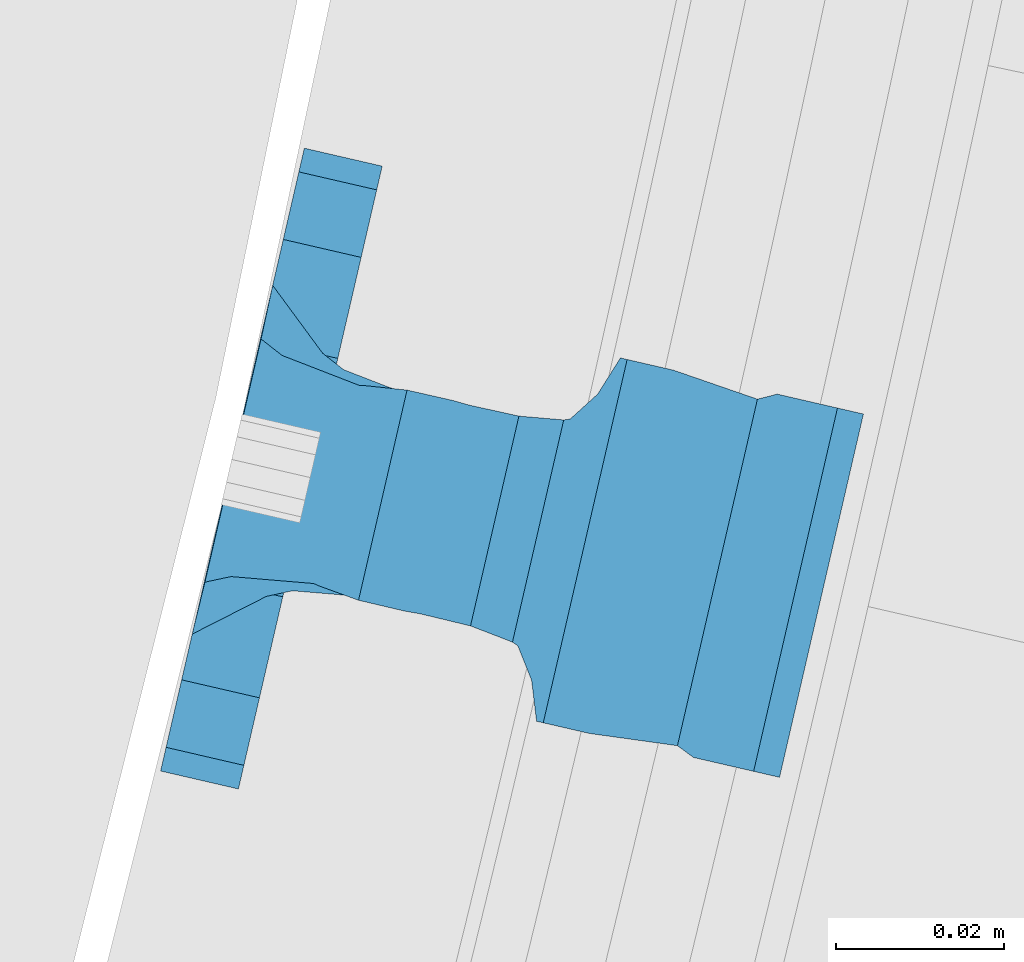
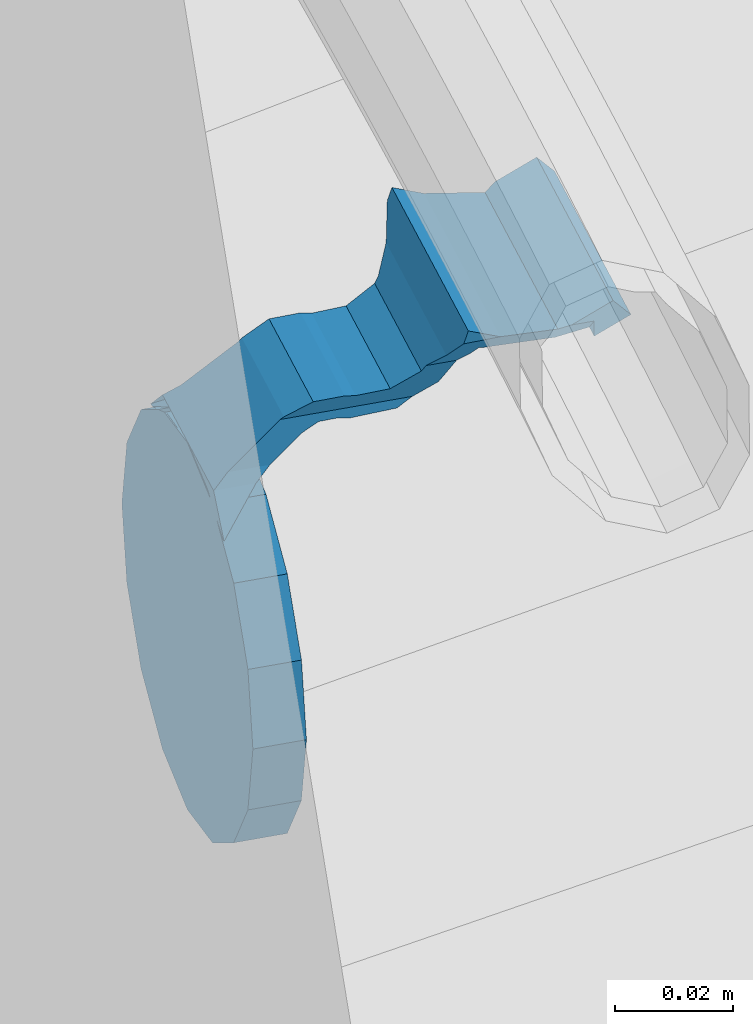
# One storey, part 504 of 975: 1 beam.
"""IFC2X3 building model written with IfcOpenShell, lengths in millimetres."""

from ifc_helpers import new_model, si_unit, frame, origin_with_axes, place, context, subcontext, project, spatial, faceted_brep, material, type_object, element, save


model = new_model("IFC2X3")

# Units and contexts
model_context = context("Model", 3, precision=1e-05, world=origin_with_axes())
body_context = subcontext(model_context, "Body", "Model", "MODEL_VIEW")
ifc_project = project(units=[si_unit("LENGTHUNIT", "METRE", prefix="MILLI"), si_unit("AREAUNIT", "SQUARE_METRE"), si_unit("VOLUMEUNIT", "CUBIC_METRE"), si_unit("MASSUNIT", "GRAM", prefix="KILO"), si_unit("TIMEUNIT", "SECOND"), si_unit("PLANEANGLEUNIT", "RADIAN"), si_unit("SOLIDANGLEUNIT", "STERADIAN"), si_unit("THERMODYNAMICTEMPERATUREUNIT", "DEGREE_CELSIUS"), si_unit("LUMINOUSINTENSITYUNIT", "LUMEN")], contexts=[model_context])

# Site, building, storey
site_placement = place(None, origin_with_axes())
site = spatial("IfcSite", under=ifc_project, at=site_placement, CompositionType="ELEMENT")
building_placement = place(site_placement, origin_with_axes())
building = spatial("IfcBuilding", under=site, at=building_placement, Name="Undefined", CompositionType="ELEMENT")
storey_placement = place(building_placement, origin_with_axes())
storey = spatial("IfcBuildingStorey", under=building, at=storey_placement, Name="Undefined", CompositionType="ELEMENT", Elevation=0.0)

# Beam
ifc_material = material(Name="STEEL/A36")
beam_type = type_object("IfcBeamType", PredefinedType="NOTDEFINED")
beam_placement = place(storey_placement, frame((38357.0730972042, 2567.26815130924, 1348.05855292862), z_axis=(0.224904224958235, 0.974380856819195, 0.000188308863012253), x_axis=(-0.974380874954763, 0.224904223989577, 2.35380000032316e-05)))
element("IfcBeam", 1, at=beam_placement, inside=storey, type_object=beam_type, material=ifc_material, Name="WALL BRACKET", context=body_context, shape_type="Brep", body=[
    faceted_brep([(-1.09139364212751e-11, -35.1998101886752, 14.5802387730655), (0.0, -26.940768363208, 26.9407683632162), (1.2732925824821e-11, -14.5802387731151, 35.1998101887366), (0.0, 0.0, 38.0999984741211), (3.27418092638254e-11, 14.5802387730973, 35.1998101888166), (3.45607986673713e-11, 26.9407683631939, 26.9407683633472), (3.27418092638254e-11, 35.1998101886679, 14.5802387732328), (2.36468622460961e-11, 38.0999999999908, 8.73114913702011e-11), (1.45519152283669e-11, 35.1998101886752, -14.5802387730655), (1.81898940354586e-12, 26.9407683632071, -26.9407683632162), (-1.09139364212751e-11, 14.5802387731146, -35.1998101887511), (0.0, 0.0, -38.0999984741211), (-2.91038304567337e-11, -14.5802387730978, -35.1998101888239), (-3.27418092638254e-11, -26.9407683631948, -26.9407683633617), (-3.09228198602796e-11, -35.1998101886688, -14.5802387732401), (-2.36468622460961e-11, -38.0999999999917, -9.45874489843845e-11), (9.52499999999407, 35.4440469783465, 13.3523775149006), (9.52500000001783, 38.099999999989, 1.23691279441118e-10), (5.45819490078651, 35.1998101886775, 14.58023877304), (5.15915812204861, 35.4440469814256, 13.3523774994246), (5.15916016817869, 35.4440461871586, -13.3523814925829), (5.45819607316758, 35.1998101886757, -14.5802387731565), (9.52499999563867, 35.4440461839649, -13.352381508641), (9.52499999999338, 33.7468954266617, -16.754679378646), (9.52499999999418, 26.9407683632057, -26.9407683631944), (7.23710514487385, 33.7468954167059, -16.7546793935435), (9.52499999997963, 14.5802387731133, -35.199810188722), (9.52499999996871, 7.73070496506989e-12, -38.1000000000931), (9.52499999996326, -14.5802387730996, -35.1998101888021), (9.52499999995962, -26.9407683631966, -26.9407683633399), (9.5249999999578, -35.1998101886768, -14.5802387731064), (9.52499999997235, -38.0999999999935, -7.27595761418343e-11), (9.52499999988504, -35.1998101886779, 14.5802387731401), (9.52499999999418, -26.9407683632098, 26.940768363238), (9.52500000000691, -14.5802387731169, 35.1998101887584), (9.52500000001783, -1.13686837721616e-11, 38.1000000001295), (9.5250000000251, 14.580238773096, 35.1998101888312), (9.52500000002692, 26.9407683631925, 26.9407683633617), (7.23710629084189, 33.7468933804012, 16.7546824409801), (9.52500001802099, 33.74689339, 16.7546824266137), (4.12737783423069, 36.2867482851609, 11.6630037101459), (9.52500001480979, 36.2867482910076, 11.6630037099276), (1.9072828969438, 38.0999998001848, -4.3824766180478e-06), (9.43529109937867, 38.0999998083389, -4.38277129433118e-06), (4.12738199474541, 36.2867456530334, -11.6630120660157), (9.52499999713365, 36.2867456588801, -11.6630120662267), (9.52499998931302, 31.8782691818908, -20.5007361535354), (1.90728516843444, 38.0999984362613, -14.9620414784949), (9.43529504267332, 38.0999984471014, -14.9620414798228), (9.52499998867484, 31.8782692100656, -21.3428983101403), (-0.974480980704527, 40.4536660864392, -13.6176374922397), (6.55352889353486, 40.4536660972792, -13.617637493564), (-3.23293929398841, 48.4467136552532, -12.2071016444133), (-3.86099316375032, 48.9596734302611, -12.3332393299024), (-3.86099415506237, 48.9596734359397, 12.1506042690053), (-3.23294234398753, 48.4467162038179, 12.0244673261113), (6.55352388489973, 40.4536689343606, 13.4350048968336), (9.4352891744017, 38.1000015670843, 14.7794093900302), (-8.88876894391092, 51.462646060533, -12.9487245784876), (-14.5044020842531, 51.5524567377918, -12.9708091785214), (-14.5044031272276, 51.5524567437842, 12.788173508583), (-8.88876998507754, 51.4626460665079, 12.7660889411018), (-16.4483770195459, 51.1442726592504, -12.8704360163174), (-16.4483780543928, 51.1442726651987, 12.6878004343525), (-22.5793182144077, 51.3711360271759, -12.9262221073186), (-22.5793192537777, 51.3711360331463, 12.7435864607032), (-27.8885284154861, 54.4455780358899, -13.6822326528272), (-27.8885295160832, 54.4455780422152, 13.4995963000001), (-28.6196515649072, 55.6169452716154, -13.9702738582564), (-31.1370083013608, 59.6501226213948, -17.5950925222933), (-31.1370097188383, 59.6501226295447, 17.4124524185645), (-28.6196545294583, 55.616948227025, 13.7876379643458), (-33.6296792490059, 67.324805151891, -22.2250062266612), (-32.8101722890036, 64.8016260361878, -22.2250061928717), (-39.3161821982224, 64.9509398614337, -22.2250064563596), (-33.6296810489844, 67.3248051619378, 22.2249937734341), (-39.3127719838823, 64.95236112884, 22.2249935438595), (-32.8101756191698, 64.8016307577993, 22.2249938072164), (-49.8281982508399, 63.7590297560901, -21.2879733583577), (-49.8281999673757, 63.7590297658239, 21.1053316176076), (-62.537662592724, 64.8016282183019, -22.2250073966388), (-62.5376643923654, 64.8016282284259, 22.2249926034456), (-59.3629825026719, 68.3509998487543, 22.2249927311568), (-59.3629807030303, 68.3509998386305, -22.2250072689349), (-56.0005505059879, 61.6533412669896, 22.2249928688907), (-56.0009816237271, 61.6535489521873, 19.2130312653135), (-56.0009816302269, 64.8016307505561, 22.0423689734525), (-51.9930603186979, 64.8016307660225, 22.2249930304133), (-51.9930486616773, 64.8016260085653, -22.2250069696784), (-56.000981616694, 61.6535497473442, -22.2250071312228), (-56.0009816212363, 64.8016260027941, -22.2250068759422), (-56.0009816161877, 61.6535496925769, -19.3956728877092), (-50.6240356350016, 59.0640018412871, -17.0683164176735), (-50.6240370098228, 59.0640018490833, 16.8856764812081), (-37.4851004069614, 60.555058921409, -18.4084041452843), (-37.4851018904596, 60.555058929803, 18.2257636742615), (-36.5628425975134, 60.9400579463424, -18.7544220673662), (-36.5628441090176, 60.9400579547794, 18.5717814508498), (-35.6661101826384, 58.1791091500552, -16.2730189810172), (-35.6661114930633, 58.1791091575863, 16.0903794298065), (-34.0669073739811, 55.616948225869, 13.7876379531408), (-34.0669044052501, 55.6169452637716, -13.9702738572996), (-31.199578137138, 51.0230652214489, -12.8406309028251), (-31.1995791695818, 51.0230652273826, 12.6579953160217), (-13.5258453474495, 46.8920843628518, -12.4814476045976), (-10.0158535806146, 46.8359491542703, -12.491353805628), (-10.0158545847443, 46.8359491600327, 12.308720278641), (-13.5258463507973, 46.8920843686235, 12.298814059428), (-15.4698202757649, 46.4839002842855, -12.5534799881534), (-15.469821284944, 46.4839002900824, 12.3708465294185), (-23.8996230795056, 46.7958284847284, -12.4984339079674), (-23.8996240842331, 46.7958284904998, 12.3158003666576), (-26.7505131823156, 48.4467136213889, -12.207101640266), (-26.7505186046602, 48.4467161988273, 12.0244672777189), (-6.87329577845111, 45.2714927334573, -12.7674339683217), (-6.87329680492121, 45.2714927393397, 12.584800790275), (-0.974485553301008, 40.4536689327629, 13.4350048813394), (1.90728014135857, 38.100001565487, 14.7794093745397), (9.52500002100476, 31.8782677827221, 21.320715892205), (9.52500002038346, 31.878267810155, 20.5007393728483)], [[[0, 1, 2, 3, 4, 5, 6, 7, 8, 9, 10, 11, 12, 13, 14, 15]], [[16, 17, 7, 6, 18, 19]], [[20, 21, 8, 7, 17, 22]], [[23, 24, 9, 8, 21, 25]], [[10, 9, 24, 26]], [[11, 10, 26, 27]], [[12, 11, 27, 28]], [[13, 12, 28, 29]], [[14, 13, 29, 30]], [[15, 14, 30, 31]], [[0, 15, 31, 32]], [[1, 0, 32, 33]], [[2, 1, 33, 34]], [[3, 2, 34, 35]], [[4, 3, 35, 36]], [[5, 4, 36, 37]], [[38, 18, 6, 5, 37, 39]], [[39, 37, 36, 35, 34, 33, 32, 31, 30, 29, 28, 27, 26, 24, 23, 22, 17, 16]], [[40, 41, 16, 19]], [[40, 42, 43, 41]], [[42, 44, 45, 43]], [[46, 23, 25]], [[47, 48, 49]], [[48, 47, 50, 51]], [[51, 52, 53, 54, 55, 56, 57, 48]], [[58, 59, 60, 61]], [[59, 62, 63, 60]], [[62, 64, 65, 63]], [[64, 66, 67, 65]], [[66, 68, 69, 70, 71, 67]], [[72, 73, 74]], [[75, 76, 77]], [[74, 76, 75, 72]], [[74, 78, 79, 76]], [[80, 81, 82, 83]], [[84, 85, 86]], [[82, 81, 84, 86, 87]], [[78, 88, 83, 82, 87, 79]], [[89, 80, 83, 88, 90]], [[89, 90, 91]], [[84, 81, 80, 89, 91, 92, 93, 85]], [[92, 94, 95, 93]], [[94, 96, 97, 95]], [[96, 98, 99, 97]], [[70, 77, 76, 79, 87, 86, 85, 93, 95, 97, 99, 100, 71]], [[69, 73, 72, 75, 77, 70]], [[68, 101, 98, 96, 94, 92, 91, 90, 88, 78, 74, 73, 69]], [[99, 98, 101, 102, 103, 100]], [[104, 105, 106, 107]], [[108, 104, 107, 109]], [[110, 108, 109, 111]], [[103, 102, 112, 110, 111, 113]], [[54, 61, 60, 63, 65, 67, 71, 100, 103, 113, 55]], [[53, 58, 61, 54]], [[52, 112, 102, 101, 68, 66, 64, 62, 59, 58, 53]], [[51, 50, 114, 105, 104, 108, 110, 112, 52]], [[105, 114, 115, 106]], [[55, 113, 111, 109, 107, 106, 115, 116, 56]], [[56, 116, 117, 57]], [[117, 118, 57]], [[39, 16, 41, 43, 45, 22, 23, 46, 49, 48, 57, 118, 119]], [[119, 38, 39]], [[119, 118, 117, 116, 115, 114, 50, 47, 49, 46, 25, 21, 20, 44, 42, 40, 19, 18, 38]], [[45, 44, 20, 22]]]),
])

save(model, "model.ifc")
